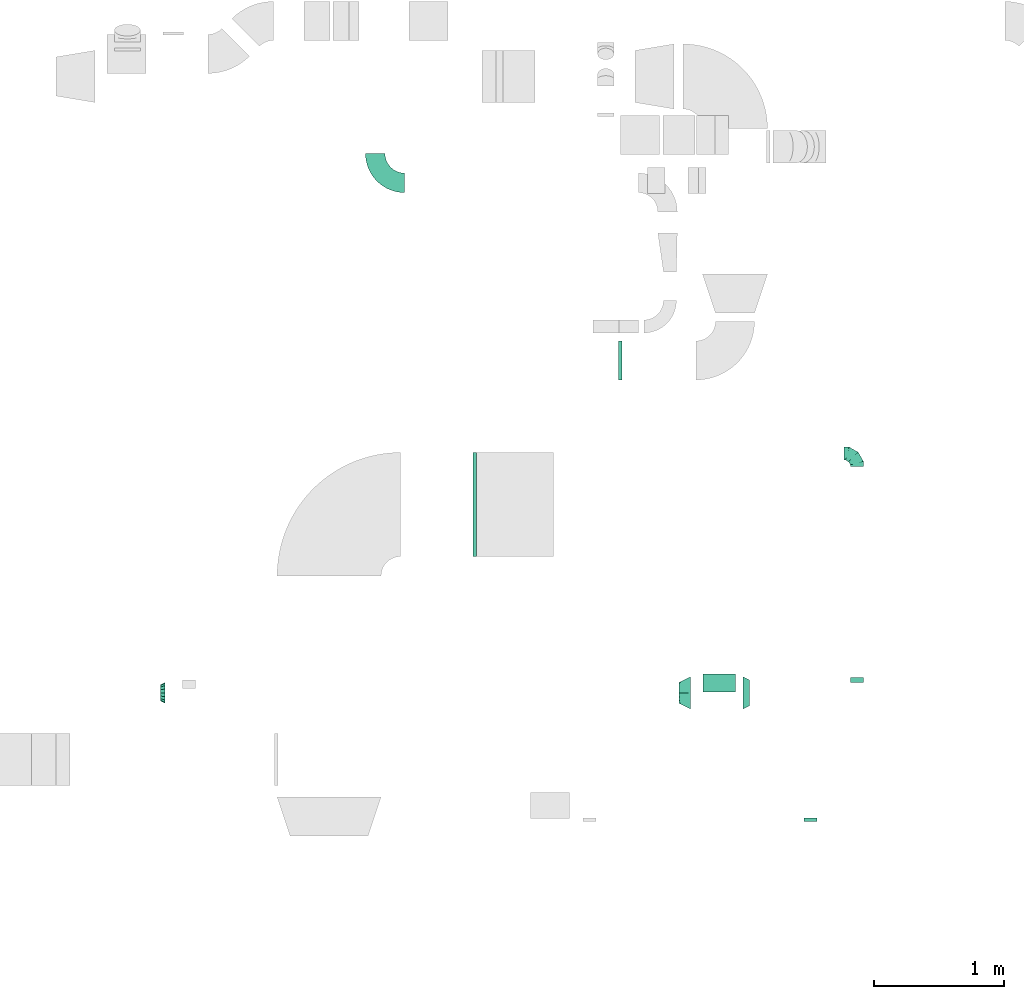
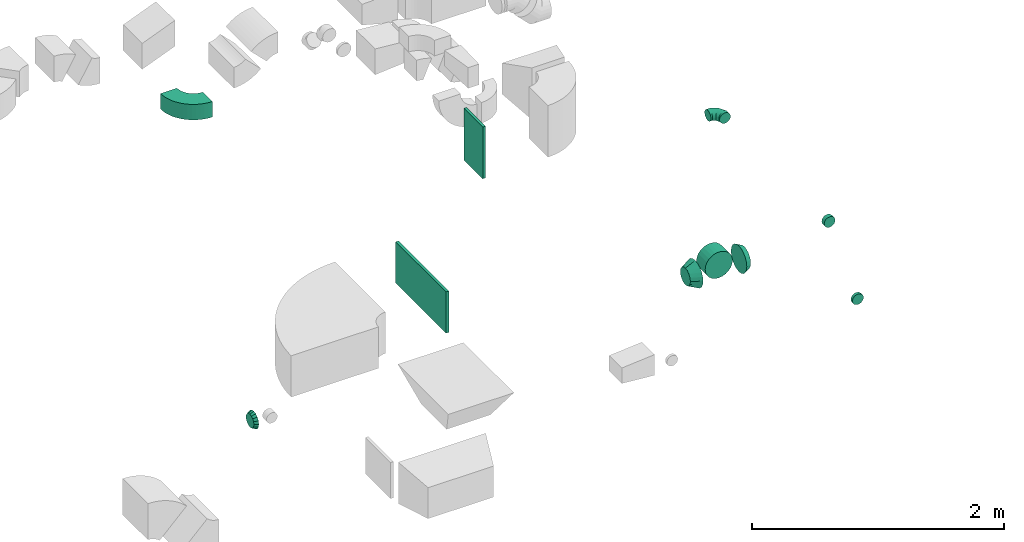
# One storey, part 25 of 44: 10 flow fittings.
"""IFC2X3 building model written with IfcOpenShell, lengths in millimetres."""

from ifc_helpers import new_model, entity, si_unit, converted_unit, derived_unit, direction, frame, frame_2d, origin, origin_2d_with_axis, place, context, subcontext, project, spatial, polyline, circle_curve, parameter, trimmed, segment, composite_curve, rectangle, outline, extrude, faceted_brep, source, transform, mapped, material, type_object, type_shapes, element, save


model = new_model("IFC2X3")

# Units and contexts
model_context = context("Model", 3, precision=0.01, world=origin(), true_north=direction((6.12303176911189e-17, 1.0)))
body_context = subcontext(model_context, "Body", "Model", "MODEL_VIEW")
ifc_project = project(units=[si_unit("LENGTHUNIT", "METRE", prefix="MILLI"), si_unit("AREAUNIT", "SQUARE_METRE"), si_unit("VOLUMEUNIT", "CUBIC_METRE"), converted_unit("PLANEANGLEUNIT", "DEGREE", entity("IfcRatioMeasure", 0.0174532925199433), si_unit("PLANEANGLEUNIT", "RADIAN"), dimensions=[0, 0, 0, 0, 0, 0, 0]), si_unit("MASSUNIT", "GRAM", prefix="KILO"), derived_unit("MASSDENSITYUNIT", [(si_unit("MASSUNIT", "GRAM", prefix="KILO"), 1), (si_unit("LENGTHUNIT", "METRE"), -3)]), derived_unit("MOMENTOFINERTIAUNIT", [(si_unit("LENGTHUNIT", "METRE"), 4)]), si_unit("TIMEUNIT", "SECOND"), si_unit("FREQUENCYUNIT", "HERTZ"), si_unit("THERMODYNAMICTEMPERATUREUNIT", "DEGREE_CELSIUS"), derived_unit("THERMALTRANSMITTANCEUNIT", [(si_unit("MASSUNIT", "GRAM", prefix="KILO"), 1), (si_unit("THERMODYNAMICTEMPERATUREUNIT", "KELVIN"), -1), (si_unit("TIMEUNIT", "SECOND"), -3)]), derived_unit("VOLUMETRICFLOWRATEUNIT", [(si_unit("LENGTHUNIT", "METRE"), 3), (si_unit("TIMEUNIT", "SECOND"), -1)]), derived_unit("MASSFLOWRATEUNIT", [(si_unit("MASSUNIT", "GRAM", prefix="KILO"), 1), (si_unit("TIMEUNIT", "SECOND"), -1)]), derived_unit("ROTATIONALFREQUENCYUNIT", [(si_unit("TIMEUNIT", "SECOND"), -1)]), si_unit("ELECTRICCURRENTUNIT", "AMPERE"), si_unit("ELECTRICVOLTAGEUNIT", "VOLT"), si_unit("POWERUNIT", "WATT"), si_unit("FORCEUNIT", "NEWTON", prefix="KILO"), si_unit("ILLUMINANCEUNIT", "LUX"), si_unit("LUMINOUSFLUXUNIT", "LUMEN"), si_unit("LUMINOUSINTENSITYUNIT", "CANDELA"), derived_unit("USERDEFINED", [(si_unit("MASSUNIT", "GRAM", prefix="KILO"), -1), (si_unit("LENGTHUNIT", "METRE"), -2), (si_unit("TIMEUNIT", "SECOND"), 3), (si_unit("LUMINOUSFLUXUNIT", "LUMEN"), 1)]), derived_unit("LINEARVELOCITYUNIT", [(si_unit("LENGTHUNIT", "METRE"), 1), (si_unit("TIMEUNIT", "SECOND"), -1)]), si_unit("PRESSUREUNIT", "PASCAL"), derived_unit("USERDEFINED", [(si_unit("LENGTHUNIT", "METRE"), -2), (si_unit("MASSUNIT", "GRAM", prefix="KILO"), 1), (si_unit("TIMEUNIT", "SECOND"), -2)]), derived_unit("LINEARFORCEUNIT", [(si_unit("MASSUNIT", "GRAM", prefix="KILO"), 1), (si_unit("LENGTHUNIT", "METRE"), 1), (si_unit("TIMEUNIT", "SECOND"), -2), (si_unit("LENGTHUNIT", "METRE"), -1)]), derived_unit("PLANARFORCEUNIT", [(si_unit("MASSUNIT", "GRAM", prefix="KILO"), 1), (si_unit("LENGTHUNIT", "METRE"), 1), (si_unit("TIMEUNIT", "SECOND"), -2), (si_unit("LENGTHUNIT", "METRE"), -2)])], contexts=[model_context])

# Site, building, storey
site_placement = place(None, origin())
site = spatial("IfcSite", under=ifc_project, at=site_placement, CompositionType="ELEMENT")
building_placement = place(site_placement, origin())
building = spatial("IfcBuilding", under=site, at=building_placement, CompositionType="ELEMENT")
storey_placement = place(building_placement, frame((0.0, 0.0, 15900.0)))
storey = spatial("IfcBuildingStorey", under=building, at=storey_placement, CompositionType="ELEMENT", Elevation=15900.0)

# Flow fittings
ifc_material = material()
duct_fitting_type_1 = type_object("IfcDuctFittingType", PredefinedType="NOTDEFINED", material=ifc_material)
shared_shape_1 = source(origin(), body_context, "Body", "SweptSolid", [
    extrude(rectangle(XDim=26.0960097170958, YDim=400.0, at=origin_2d_with_axis()), frame((6.95, 0.0, -400.0)), (0.0, 0.0, 1.0), 800.0),
])
type_shapes(duct_fitting_type_1, [shared_shape_1])
flow_fitting_1_placement = place(storey_placement, frame((51645.21, 11685.33, 2920.0), z_axis=(0.0, 1.0, 0.0), x_axis=(-1.0, 0.0, -1.21463647590417e-08)))
element("IfcFlowFitting", 1, at=flow_fitting_1_placement, inside=storey, type_object=duct_fitting_type_1, material=ifc_material, context=body_context, shape_type="MappedRepresentation", body=[
    mapped(shared_shape_1, transform((0.0, 0.0, 0.0), scale=1.0)),
])
duct_fitting_type_2 = type_object("IfcDuctFittingType", PredefinedType="NOTDEFINED", material=ifc_material)
shared_shape_2 = source(origin(), body_context, "Body", "SweptSolid", [
    extrude(rectangle(XDim=26.1144802646983, YDim=500.0, at=origin_2d_with_axis()), frame((6.96, 0.0, -150.0)), (0.0, 0.0, 1.0), 300.0),
])
type_shapes(duct_fitting_type_2, [shared_shape_2])
flow_fitting_2_placement = place(storey_placement, frame((52750.19, 12792.39, 3250.0), z_axis=(0.0, -1.0, 0.0), x_axis=(1.0, 0.0, 0.0)))
element("IfcFlowFitting", 2, at=flow_fitting_2_placement, inside=storey, type_object=duct_fitting_type_2, material=ifc_material, context=body_context, shape_type="MappedRepresentation", body=[
    mapped(shared_shape_2, transform((0.0, 0.0, 0.0), scale=1.0)),
])
duct_fitting_type_3 = type_object("IfcDuctFittingType", PredefinedType="NOTDEFINED", material=ifc_material)
shared_shape_3 = source(origin(), body_context, "Body", "Brep", [
    faceted_brep([(-100.0, 0.0, -50.0), (-100.0, -12.94, -48.3), (-100.0, -25.0, -43.3), (-100.0, -35.36, -35.36), (-100.0, -43.3, -25.0), (-100.0, -48.3, -12.94), (-100.0, -50.0, 0.0), (-100.0, -48.3, 12.94), (-100.0, -43.3, 25.0), (-100.0, -35.36, 35.36), (-100.0, -25.0, 43.3), (-100.0, -12.94, 48.3), (-100.0, 0.0, 50.0), (-100.0, 12.94, 48.3), (-100.0, 25.0, 43.3), (-100.0, 35.36, 35.36), (-100.0, 43.3, 25.0), (-100.0, 48.3, 12.94), (-100.0, 50.0, 0.0), (-100.0, 48.3, -12.94), (-100.0, 43.3, -25.0), (-100.0, 35.36, -35.36), (-100.0, 25.0, -43.3), (-100.0, 12.94, -48.3), (-76.67, 12.94, 48.3), (-79.9, 25.0, 43.3), (-73.21, 0.0, 50.0), (-82.68, 35.36, 35.36), (-86.15, 48.3, 12.94), (-86.6, 50.0, 0.0), (-84.81, 43.3, 25.0), (-84.81, 43.3, -25.0), (-82.68, 35.36, -35.36), (-86.15, 48.3, -12.94), (-76.67, 12.94, -48.3), (-73.21, 0.0, -50.0), (-79.9, 25.0, -43.3), (-69.74, -12.94, -48.3), (-66.51, -25.0, -43.3), (-63.73, -35.36, -35.36), (-61.6, -43.3, -25.0), (-60.26, -48.3, -12.94), (-59.81, -50.0, 0.0), (-60.26, -48.3, 12.94), (-61.6, -43.3, 25.0), (-63.73, -35.36, 35.36), (-66.51, -25.0, 43.3), (-69.74, -12.94, 48.3), (-36.27, 36.27, 48.3), (-45.1, 45.1, 43.3), (-26.79, 26.79, 50.0), (-52.68, 52.68, 35.36), (-58.49, 58.49, 25.0), (-62.15, 62.15, 12.94), (-63.4, 63.4, 0.0), (-62.15, 62.15, -12.94), (-58.49, 58.49, -25.0), (-52.68, 52.68, -35.36), (-36.27, 36.27, -48.3), (-26.79, 26.79, -50.0), (-45.1, 45.1, -43.3), (-17.32, 17.32, -48.3), (-8.49, 8.49, -43.3), (-0.91, 0.91, -35.36), (4.9, -4.9, -25.0), (8.56, -8.56, -12.94), (9.81, -9.81, 0.0), (8.56, -8.56, 12.94), (4.9, -4.9, 25.0), (-0.91, 0.91, 35.36), (-8.49, 8.49, 43.3), (-17.32, 17.32, 48.3), (-12.94, 76.67, 48.3), (-25.0, 79.9, 43.3), (0.0, 73.21, 50.0), (-35.36, 82.68, 35.36), (-43.3, 84.81, 25.0), (-48.3, 86.15, 12.94), (-50.0, 86.6, 0.0), (-48.3, 86.15, -12.94), (-43.3, 84.81, -25.0), (-35.36, 82.68, -35.36), (-12.94, 76.67, -48.3), (0.0, 73.21, -50.0), (-25.0, 79.9, -43.3), (12.94, 69.74, -48.3), (25.0, 66.51, -43.3), (35.36, 63.73, -35.36), (43.3, 61.6, -25.0), (48.3, 60.26, -12.94), (50.0, 59.81, 0.0), (48.3, 60.26, 12.94), (43.3, 61.6, 25.0), (35.36, 63.73, 35.36), (25.0, 66.51, 43.3), (12.94, 69.74, 48.3), (-12.94, 100.0, -48.3), (-25.0, 100.0, -43.3), (-35.36, 100.0, -35.36), (-43.3, 100.0, -25.0), (-48.3, 100.0, -12.94), (-50.0, 100.0, 0.0), (-48.3, 100.0, 12.94), (-43.3, 100.0, 25.0), (-35.36, 100.0, 35.36), (-25.0, 100.0, 43.3), (-12.94, 100.0, 48.3), (0.0, 100.0, 50.0), (12.94, 100.0, 48.3), (25.0, 100.0, 43.3), (35.36, 100.0, 35.36), (43.3, 100.0, 25.0), (48.3, 100.0, 12.94), (50.0, 100.0, 0.0), (48.3, 100.0, -12.94), (43.3, 100.0, -25.0), (35.36, 100.0, -35.36), (25.0, 100.0, -43.3), (12.94, 100.0, -48.3), (0.0, 100.0, -50.0)], [[[0, 1, 2, 3, 4, 5, 6, 7, 8, 9, 10, 11, 12, 13, 14, 15, 16, 17, 18, 19, 20, 21, 22, 23]], [[24, 25, 14, 13]], [[26, 24, 13, 12]], [[14, 25, 27, 15]], [[28, 29, 18, 17]], [[30, 28, 17, 16]], [[15, 27, 30, 16]], [[20, 31, 32, 21]], [[33, 31, 20, 19]], [[18, 29, 33, 19]], [[34, 35, 0, 23]], [[36, 34, 23, 22]], [[32, 36, 22, 21]], [[2, 1, 37, 38]], [[3, 2, 38, 39]], [[0, 35, 37, 1]], [[5, 4, 40, 41]], [[6, 5, 41, 42]], [[3, 39, 40, 4]], [[6, 42, 43, 7]], [[7, 43, 44, 8]], [[8, 44, 45, 9]], [[10, 46, 47, 11]], [[11, 47, 26, 12]], [[10, 9, 45, 46]], [[48, 49, 25, 24]], [[50, 48, 24, 26]], [[27, 25, 49, 51]], [[52, 53, 28, 30]], [[51, 52, 30, 27]], [[29, 28, 53, 54]], [[55, 56, 31, 33]], [[54, 55, 33, 29]], [[57, 32, 31, 56]], [[58, 59, 35, 34]], [[60, 58, 34, 36]], [[57, 60, 36, 32]], [[37, 35, 59, 61]], [[38, 37, 61, 62]], [[39, 38, 62, 63]], [[41, 40, 64, 65]], [[42, 41, 65, 66]], [[63, 64, 40, 39]], [[43, 42, 66, 67]], [[44, 43, 67, 68]], [[68, 69, 45, 44]], [[46, 45, 69, 70]], [[47, 46, 70, 71]], [[26, 47, 71, 50]], [[72, 73, 49, 48]], [[74, 72, 48, 50]], [[51, 49, 73, 75]], [[76, 77, 53, 52]], [[75, 76, 52, 51]], [[54, 53, 77, 78]], [[79, 80, 56, 55]], [[78, 79, 55, 54]], [[81, 57, 56, 80]], [[82, 83, 59, 58]], [[84, 82, 58, 60]], [[81, 84, 60, 57]], [[61, 59, 83, 85]], [[62, 61, 85, 86]], [[63, 62, 86, 87]], [[65, 64, 88, 89]], [[66, 65, 89, 90]], [[87, 88, 64, 63]], [[67, 66, 90, 91]], [[68, 67, 91, 92]], [[92, 93, 69, 68]], [[70, 69, 93, 94]], [[71, 70, 94, 95]], [[50, 71, 95, 74]], [[96, 97, 98, 99, 100, 101, 102, 103, 104, 105, 106, 107, 108, 109, 110, 111, 112, 113, 114, 115, 116, 117, 118, 119]], [[72, 74, 107, 106]], [[73, 72, 106, 105]], [[75, 73, 105, 104]], [[77, 76, 103, 102]], [[78, 77, 102, 101]], [[75, 104, 103, 76]], [[78, 101, 100, 79]], [[79, 100, 99, 80]], [[80, 99, 98, 81]], [[96, 119, 83, 82]], [[97, 96, 82, 84]], [[84, 81, 98, 97]], [[83, 119, 118, 85]], [[85, 118, 117, 86]], [[86, 117, 116, 87]], [[88, 115, 114, 89]], [[89, 114, 113, 90]], [[87, 116, 115, 88]], [[91, 90, 113, 112]], [[92, 91, 112, 111]], [[93, 92, 111, 110]], [[95, 94, 109, 108]], [[74, 95, 108, 107]], [[110, 109, 94, 93]]]),
])
type_shapes(duct_fitting_type_3, [shared_shape_3])
flow_fitting_3_placement = place(storey_placement, frame((54577.18, 12076.8, 3350.0), z_axis=(0.0, -5.84723969274682e-07, 1.0), x_axis=(0.0, 1.0, 5.84723969274682e-07)))
element("IfcFlowFitting", 3, at=flow_fitting_3_placement, inside=storey, type_object=duct_fitting_type_3, material=ifc_material, context=body_context, shape_type="MappedRepresentation", body=[
    mapped(shared_shape_3, transform((0.0, 0.0, 0.0), scale=1.0)),
])
duct_fitting_type_4 = type_object("IfcDuctFittingType", PredefinedType="NOTDEFINED", material=ifc_material)
shared_shape_4 = source(origin(), body_context, "Body", "Brep", [
    faceted_brep([(35.0, -57.74, 23.92), (35.0, -60.12, 11.96), (35.0, -62.5, 0.0), (35.0, -60.12, -11.96), (35.0, -57.74, -23.92), (35.0, -50.97, -34.06), (35.0, -44.19, -44.19), (35.0, -34.06, -50.97), (35.0, -23.92, -57.74), (35.0, -11.96, -60.12), (35.0, 0.0, -62.5), (35.0, 11.96, -60.12), (35.0, 23.92, -57.74), (35.0, 34.06, -50.97), (35.0, 44.19, -44.19), (35.0, 50.97, -34.06), (35.0, 57.74, -23.92), (35.0, 60.12, -11.96), (35.0, 62.5, 0.0), (35.0, 60.12, 11.96), (35.0, 57.74, 23.92), (35.0, 50.97, 34.06), (35.0, 44.19, 44.19), (35.0, 34.06, 50.97), (35.0, 23.92, 57.74), (35.0, 11.96, 60.12), (35.0, 0.0, 62.5), (35.0, -11.96, 60.12), (35.0, -23.92, 57.74), (35.0, -34.06, 50.97), (35.0, -44.19, 44.19), (35.0, -50.97, 34.06), (0.0, -80.0, 0.0), (0.0, -77.45, 12.81), (0.0, -73.91, 30.61), (0.0, -65.24, 43.59), (0.0, -56.57, 56.57), (0.0, -43.59, 65.24), (0.0, -30.61, 73.91), (0.0, -12.81, 77.45), (0.0, 0.0, 80.0), (0.0, 12.81, 77.45), (0.0, 30.61, 73.91), (0.0, 43.59, 65.24), (0.0, 56.57, 56.57), (0.0, 65.24, 43.59), (0.0, 73.91, 30.61), (0.0, 77.45, 12.81), (0.0, 80.0, 0.0), (0.0, 77.45, -12.81), (0.0, 73.91, -30.61), (0.0, 65.24, -43.59), (0.0, 56.57, -56.57), (0.0, 43.59, -65.24), (0.0, 30.61, -73.91), (0.0, 12.81, -77.45), (0.0, 0.0, -80.0), (0.0, -12.81, -77.45), (0.0, -30.61, -73.91), (0.0, -43.59, -65.24), (0.0, -56.57, -56.57), (0.0, -65.24, -43.59), (0.0, -73.91, -30.61), (0.0, -77.45, -12.81)], [[[0, 1, 2, 3, 4, 5, 6, 7, 8, 9, 10, 11, 12, 13, 14, 15, 16, 17, 18, 19, 20, 21, 22, 23, 24, 25, 26, 27, 28, 29, 30, 31]], [[32, 33, 34, 35, 36, 37, 38, 39, 40, 41, 42, 43, 44, 45, 46, 47, 48, 49, 50, 51, 52, 53, 54, 55, 56, 57, 58, 59, 60, 61, 62, 63]], [[24, 23, 22, 44, 43, 42]], [[20, 46, 45, 44, 22, 21]], [[42, 41, 40, 26, 25, 24]], [[47, 46, 20, 19, 18, 48]], [[0, 31, 30, 36, 35, 34]], [[28, 38, 37, 36, 30, 29]], [[34, 33, 32, 2, 1, 0]], [[39, 38, 28, 27, 26, 40]], [[8, 7, 6, 60, 59, 58]], [[4, 62, 61, 60, 6, 5]], [[58, 57, 56, 10, 9, 8]], [[63, 62, 4, 3, 2, 32]], [[16, 15, 14, 52, 51, 50]], [[12, 54, 53, 52, 14, 13]], [[50, 49, 48, 18, 17, 16]], [[55, 54, 12, 11, 10, 56]]]),
])
type_shapes(duct_fitting_type_4, [shared_shape_4])
flow_fitting_4_placement = place(storey_placement, frame((49259.89, 10237.4, 3350.0), z_axis=(0.0, 0.0, 1.0), x_axis=(-1.0, 0.0, 0.0)))
element("IfcFlowFitting", 4, at=flow_fitting_4_placement, inside=storey, type_object=duct_fitting_type_4, material=ifc_material, context=body_context, shape_type="MappedRepresentation", body=[
    mapped(shared_shape_4, transform((0.0, 0.0, 0.0), scale=1.0)),
])
duct_fitting_type_5 = type_object("IfcDuctFittingType", PredefinedType="NOTDEFINED", material=ifc_material)
shared_shape_5 = source(origin(), body_context, "Body", "Brep", [
    faceted_brep([(90.0, -73.91, 30.61), (90.0, -76.96, 15.31), (90.0, -80.0, 0.0), (90.0, -76.96, -15.31), (90.0, -73.91, -30.61), (90.0, -65.24, -43.59), (90.0, -56.57, -56.57), (90.0, -43.59, -65.24), (90.0, -30.61, -73.91), (90.0, -15.31, -76.96), (90.0, 0.0, -80.0), (90.0, 15.31, -76.96), (90.0, 30.61, -73.91), (90.0, 43.59, -65.24), (90.0, 56.57, -56.57), (90.0, 65.24, -43.59), (90.0, 73.91, -30.61), (90.0, 76.96, -15.31), (90.0, 80.0, 0.0), (90.0, 76.96, 15.31), (90.0, 73.91, 30.61), (90.0, 65.24, 43.59), (90.0, 56.57, 56.57), (90.0, 43.59, 65.24), (90.0, 30.61, 73.91), (90.0, 15.31, 76.96), (90.0, 0.0, 80.0), (90.0, -15.31, 76.96), (90.0, -30.61, 73.91), (90.0, -43.59, 65.24), (90.0, -56.57, 56.57), (90.0, -65.24, 43.59), (0.0, -125.0, 0.0), (0.0, -118.88, 38.63), (0.0, -101.13, 73.47), (0.0, -73.47, 101.13), (0.0, -38.63, 118.88), (0.0, 0.0, 125.0), (0.0, 38.63, 118.88), (0.0, 73.47, 101.13), (0.0, 101.13, 73.47), (0.0, 118.88, 38.63), (0.0, 125.0, 0.0), (0.0, 118.88, -38.63), (0.0, 101.13, -73.47), (0.0, 73.47, -101.13), (0.0, 38.63, -118.88), (0.0, 0.0, -125.0), (0.0, -38.63, -118.88), (0.0, -73.47, -101.13), (0.0, -101.13, -73.47), (0.0, -118.88, -38.63)], [[[0, 1, 2, 3, 4, 5, 6, 7, 8, 9, 10, 11, 12, 13, 14, 15, 16, 17, 18, 19, 20, 21, 22, 23, 24, 25, 26, 27, 28, 29, 30, 31]], [[32, 33, 34, 35, 36, 37, 38, 39, 40, 41, 42, 43, 44, 45, 46, 47, 48, 49, 50, 51]], [[37, 25, 38]], [[24, 39, 38]], [[40, 22, 21, 20]], [[23, 22, 39, 24]], [[41, 20, 19]], [[18, 42, 19]], [[25, 24, 38]], [[40, 20, 41]], [[19, 42, 41]], [[25, 37, 26]], [[22, 40, 39]], [[32, 1, 33]], [[0, 34, 33]], [[35, 30, 29, 28]], [[31, 30, 34, 0]], [[36, 28, 27]], [[26, 37, 27]], [[1, 0, 33]], [[35, 28, 36]], [[27, 37, 36]], [[1, 32, 2]], [[30, 35, 34]], [[47, 9, 48]], [[8, 49, 48]], [[50, 6, 5, 4]], [[7, 6, 49, 8]], [[51, 4, 3]], [[2, 32, 3]], [[9, 8, 48]], [[50, 4, 51]], [[3, 32, 51]], [[9, 47, 10]], [[6, 50, 49]], [[42, 17, 43]], [[16, 44, 43]], [[45, 14, 13, 12]], [[15, 14, 44, 16]], [[46, 12, 11]], [[10, 47, 11]], [[17, 16, 43]], [[45, 12, 46]], [[11, 47, 46]], [[17, 42, 18]], [[14, 45, 44]]]),
])
type_shapes(duct_fitting_type_5, [shared_shape_5])
flow_fitting_5_placement = place(storey_placement, frame((53299.89, 10237.4, 3350.0), z_axis=(0.0, 0.0, 1.0), x_axis=(-1.0, 0.0, 0.0)))
element("IfcFlowFitting", 5, at=flow_fitting_5_placement, inside=storey, type_object=duct_fitting_type_5, material=ifc_material, context=body_context, shape_type="MappedRepresentation", body=[
    mapped(shared_shape_5, transform((0.0, 0.0, 0.0), scale=1.0)),
])
duct_fitting_type_6 = type_object("IfcDuctFittingType", PredefinedType="NOTDEFINED", material=ifc_material)
shared_shape_6 = source(origin(), body_context, "Body", "Brep", [
    faceted_brep([(20.0, 0.0, -50.0), (20.0, 12.94, -48.3), (20.0, 25.0, -43.3), (20.0, 35.36, -35.36), (20.0, 43.3, -25.0), (20.0, 48.3, -12.94), (20.0, 50.0, 0.0), (20.0, 48.3, 12.94), (20.0, 43.3, 25.0), (20.0, 35.36, 35.36), (20.0, 25.0, 43.3), (20.0, 12.94, 48.3), (20.0, 0.0, 50.0), (20.0, -12.94, 48.3), (20.0, -25.0, 43.3), (20.0, -35.36, 35.36), (20.0, -43.3, 25.0), (20.0, -48.3, 12.94), (20.0, -50.0, 0.0), (20.0, -48.3, -12.94), (20.0, -43.3, -25.0), (20.0, -35.36, -35.36), (20.0, -25.0, -43.3), (20.0, -12.94, -48.3), (0.0, 0.0, 50.0), (-6.1, 0.0, 50.0), (-6.1, -12.94, 48.3), (0.0, -12.94, 48.3), (-6.1, -25.0, 43.3), (0.0, -25.0, 43.3), (0.0, -35.36, 35.36), (-6.1, -35.36, 35.36), (0.0, -43.3, 25.0), (-6.1, -43.3, 25.0), (-6.1, -48.3, 12.94), (0.0, -48.3, 12.94), (-6.1, -50.0, 0.0), (0.0, -50.0, 0.0), (-6.1, -48.3, -12.94), (0.0, -48.3, -12.94), (-6.1, -43.3, -25.0), (0.0, -43.3, -25.0), (0.0, -35.36, -35.36), (-6.1, -35.36, -35.36), (0.0, -25.0, -43.3), (-6.1, -25.0, -43.3), (-6.1, -12.94, -48.3), (0.0, -12.94, -48.3), (-6.1, 0.0, -50.0), (0.0, 0.0, -50.0), (-6.1, 12.94, -48.3), (0.0, 12.94, -48.3), (-6.1, 25.0, -43.3), (0.0, 25.0, -43.3), (0.0, 35.36, -35.36), (-6.1, 35.36, -35.36), (0.0, 43.3, -25.0), (-6.1, 43.3, -25.0), (-6.1, 48.3, -12.94), (0.0, 48.3, -12.94), (-6.1, 50.0, 0.0), (0.0, 50.0, 0.0), (-6.1, 48.3, 12.94), (0.0, 48.3, 12.94), (-6.1, 43.3, 25.0), (0.0, 43.3, 25.0), (0.0, 35.36, 35.36), (-6.1, 35.36, 35.36), (0.0, 25.0, 43.3), (-6.1, 25.0, 43.3), (-6.1, 12.94, 48.3), (0.0, 12.94, 48.3)], [[[0, 1, 2, 3, 4, 5, 6, 7, 8, 9, 10, 11, 12, 13, 14, 15, 16, 17, 18, 19, 20, 21, 22, 23]], [[13, 12, 24, 25, 26, 27]], [[14, 13, 27, 26, 28, 29]], [[30, 15, 14, 29, 28, 31]], [[17, 16, 32, 33, 34, 35]], [[18, 17, 35, 34, 36, 37]], [[32, 16, 15, 30, 31, 33]], [[19, 18, 37, 36, 38, 39]], [[20, 19, 39, 38, 40, 41]], [[42, 21, 20, 41, 40, 43]], [[23, 22, 44, 45, 46, 47]], [[0, 23, 47, 46, 48, 49]], [[44, 22, 21, 42, 43, 45]], [[1, 0, 49, 48, 50, 51]], [[2, 1, 51, 50, 52, 53]], [[54, 3, 2, 53, 52, 55]], [[5, 4, 56, 57, 58, 59]], [[6, 5, 59, 58, 60, 61]], [[56, 4, 3, 54, 55, 57]], [[7, 6, 61, 60, 62, 63]], [[8, 7, 63, 62, 64, 65]], [[66, 9, 8, 65, 64, 67]], [[11, 10, 68, 69, 70, 71]], [[12, 11, 71, 70, 25, 24]], [[68, 10, 9, 66, 67, 69]], [[46, 45, 43, 40, 38, 36, 34, 33, 31, 28, 26, 25, 70, 69, 67, 64, 62, 60, 58, 57, 55, 52, 50, 48]]]),
])
type_shapes(duct_fitting_type_6, [shared_shape_6])
flow_fitting_6_placement = place(storey_placement, frame((54219.55, 9270.12, 3375.0), z_axis=(0.0, 0.0, -1.0), x_axis=(0.0, -1.0, 0.0)))
element("IfcFlowFitting", 6, at=flow_fitting_6_placement, inside=storey, type_object=duct_fitting_type_6, material=ifc_material, context=body_context, shape_type="MappedRepresentation", body=[
    mapped(shared_shape_6, transform((0.0, 0.0, 0.0), scale=1.0)),
])
duct_fitting_type_7 = type_object("IfcDuctFittingType", PredefinedType="NOTDEFINED", material=ifc_material)
shared_shape_7 = source(origin(), body_context, "Body", "Brep", [
    faceted_brep([(20.0, 0.0, -50.0), (20.0, 12.94, -48.3), (20.0, 25.0, -43.3), (20.0, 35.36, -35.36), (20.0, 43.3, -25.0), (20.0, 48.3, -12.94), (20.0, 50.0, 0.0), (20.0, 48.3, 12.94), (20.0, 43.3, 25.0), (20.0, 35.36, 35.36), (20.0, 25.0, 43.3), (20.0, 12.94, 48.3), (20.0, 0.0, 50.0), (20.0, -12.94, 48.3), (20.0, -25.0, 43.3), (20.0, -35.36, 35.36), (20.0, -43.3, 25.0), (20.0, -48.3, 12.94), (20.0, -50.0, 0.0), (20.0, -48.3, -12.94), (20.0, -43.3, -25.0), (20.0, -35.36, -35.36), (20.0, -25.0, -43.3), (20.0, -12.94, -48.3), (0.0, 0.0, 50.0), (-19.49, 0.0, 50.0), (-19.49, -12.94, 48.3), (0.0, -12.94, 48.3), (-19.49, -25.0, 43.3), (0.0, -25.0, 43.3), (0.0, -35.36, 35.36), (-19.49, -35.36, 35.36), (0.0, -43.3, 25.0), (-19.49, -43.3, 25.0), (-19.49, -48.3, 12.94), (0.0, -48.3, 12.94), (-19.49, -50.0, 0.0), (0.0, -50.0, 0.0), (-19.49, -48.3, -12.94), (0.0, -48.3, -12.94), (-19.49, -43.3, -25.0), (0.0, -43.3, -25.0), (0.0, -35.36, -35.36), (-19.49, -35.36, -35.36), (0.0, -25.0, -43.3), (-19.49, -25.0, -43.3), (-19.49, -12.94, -48.3), (0.0, -12.94, -48.3), (-19.49, 0.0, -50.0), (0.0, 0.0, -50.0), (-19.49, 12.94, -48.3), (0.0, 12.94, -48.3), (-19.49, 25.0, -43.3), (0.0, 25.0, -43.3), (0.0, 35.36, -35.36), (-19.49, 35.36, -35.36), (0.0, 43.3, -25.0), (-19.49, 43.3, -25.0), (-19.49, 48.3, -12.94), (0.0, 48.3, -12.94), (-19.49, 50.0, 0.0), (0.0, 50.0, 0.0), (-19.49, 48.3, 12.94), (0.0, 48.3, 12.94), (-19.49, 43.3, 25.0), (0.0, 43.3, 25.0), (0.0, 35.36, 35.36), (-19.49, 35.36, 35.36), (0.0, 25.0, 43.3), (-19.49, 25.0, 43.3), (-19.49, 12.94, 48.3), (0.0, 12.94, 48.3)], [[[0, 1, 2, 3, 4, 5, 6, 7, 8, 9, 10, 11, 12, 13, 14, 15, 16, 17, 18, 19, 20, 21, 22, 23]], [[13, 12, 24, 25, 26, 27]], [[14, 13, 27, 26, 28, 29]], [[30, 15, 14, 29, 28, 31]], [[17, 16, 32, 33, 34, 35]], [[18, 17, 35, 34, 36, 37]], [[32, 16, 15, 30, 31, 33]], [[19, 18, 37, 36, 38, 39]], [[20, 19, 39, 38, 40, 41]], [[42, 21, 20, 41, 40, 43]], [[23, 22, 44, 45, 46, 47]], [[0, 23, 47, 46, 48, 49]], [[44, 22, 21, 42, 43, 45]], [[1, 0, 49, 48, 50, 51]], [[2, 1, 51, 50, 52, 53]], [[54, 3, 2, 53, 52, 55]], [[5, 4, 56, 57, 58, 59]], [[6, 5, 59, 58, 60, 61]], [[56, 4, 3, 54, 55, 57]], [[7, 6, 61, 60, 62, 63]], [[8, 7, 63, 62, 64, 65]], [[66, 9, 8, 65, 64, 67]], [[11, 10, 68, 69, 70, 71]], [[12, 11, 71, 70, 25, 24]], [[68, 10, 9, 66, 67, 69]], [[46, 45, 43, 40, 38, 36, 34, 33, 31, 28, 26, 25, 70, 69, 67, 64, 62, 60, 58, 57, 55, 52, 50, 48]]]),
])
type_shapes(duct_fitting_type_7, [shared_shape_7])
flow_fitting_7_placement = place(storey_placement, frame((54577.18, 10337.4, 3350.0), z_axis=(0.0, 5.84723967977052e-07, -1.0), x_axis=(0.0, 1.0, 5.84723967700733e-07)))
element("IfcFlowFitting", 7, at=flow_fitting_7_placement, inside=storey, type_object=duct_fitting_type_7, material=ifc_material, context=body_context, shape_type="MappedRepresentation", body=[
    mapped(shared_shape_7, transform((0.0, 0.0, 0.0), scale=1.0)),
])
duct_fitting_type_8 = type_object("IfcDuctFittingType", PredefinedType="NOTDEFINED", material=ifc_material)
shared_shape_8 = source(origin(), body_context, "Body", "Brep", [
    faceted_brep([(50.0, -73.47, -101.13), (50.0, -38.63, -118.88), (50.0, 0.0, -125.0), (50.0, 38.63, -118.88), (50.0, 73.47, -101.13), (50.0, 101.13, -73.47), (50.0, 118.88, -38.63), (50.0, 125.0, 0.0), (50.0, 118.88, 38.63), (50.0, 101.13, 73.47), (50.0, 73.47, 101.13), (50.0, 38.63, 118.88), (50.0, 0.0, 125.0), (50.0, -38.63, 118.88), (50.0, -73.47, 101.13), (50.0, -101.13, 73.47), (50.0, -118.88, 38.63), (50.0, -125.0, 0.0), (50.0, -118.88, -38.63), (50.0, -101.13, -73.47), (0.0, 30.9, -95.11), (0.0, 0.0, -100.0), (0.0, -30.9, -95.11), (0.0, -58.78, -80.9), (0.0, -80.9, -58.78), (0.0, -95.11, -30.9), (0.0, -100.0, 0.0), (0.0, -95.11, 30.9), (0.0, -80.9, 58.78), (0.0, -58.78, 80.9), (0.0, -30.9, 95.11), (0.0, 0.0, 100.0), (0.0, 30.9, 95.11), (0.0, 58.78, 80.9), (0.0, 80.9, 58.78), (0.0, 95.11, 30.9), (0.0, 100.0, 0.0), (0.0, 95.11, -30.9), (0.0, 80.9, -58.78), (0.0, 58.78, -80.9)], [[[0, 1, 2, 3, 4, 5, 6, 7, 8, 9, 10, 11, 12, 13, 14, 15, 16, 17, 18, 19]], [[20, 21, 22, 23, 24, 25, 26, 27, 28, 29, 30, 31, 32, 33, 34, 35, 36, 37, 38, 39]], [[35, 34, 9, 8]], [[36, 35, 8, 7]], [[34, 33, 10, 9]], [[10, 33, 32, 11]], [[11, 32, 31, 12]], [[30, 29, 14, 13]], [[31, 30, 13, 12]], [[29, 28, 15, 14]], [[15, 28, 27, 16]], [[16, 27, 26, 17]], [[25, 24, 19, 18]], [[26, 25, 18, 17]], [[24, 23, 0, 19]], [[0, 23, 22, 1]], [[1, 22, 21, 2]], [[20, 39, 4, 3]], [[21, 20, 3, 2]], [[39, 38, 5, 4]], [[5, 38, 37, 6]], [[6, 37, 36, 7]]]),
])
type_shapes(duct_fitting_type_8, [shared_shape_8])
flow_fitting_8_placement = place(storey_placement, frame((53749.89, 10237.4, 3350.0), z_axis=(0.0, 0.0, 1.0), x_axis=(-1.0, 0.0, 0.0)))
element("IfcFlowFitting", 8, at=flow_fitting_8_placement, inside=storey, type_object=duct_fitting_type_8, material=ifc_material, context=body_context, shape_type="MappedRepresentation", body=[
    mapped(shared_shape_8, transform((0.0, 0.0, 0.0), scale=1.0)),
])
duct_fitting_type_9 = type_object("IfcDuctFittingType", PredefinedType="NOTDEFINED", material=ifc_material)
shared_shape_9 = source(origin(), body_context, "Body", "Brep", [
    faceted_brep([(20.0, 0.0, -125.0), (20.0, 32.35, -120.74), (20.0, 62.5, -108.25), (20.0, 88.39, -88.39), (20.0, 108.25, -62.5), (20.0, 120.74, -32.35), (20.0, 125.0, 0.0), (20.0, 120.74, 32.35), (20.0, 108.25, 62.5), (20.0, 88.39, 88.39), (20.0, 62.5, 108.25), (20.0, 32.35, 120.74), (20.0, 0.0, 125.0), (20.0, -32.35, 120.74), (20.0, -62.5, 108.25), (20.0, -88.39, 88.39), (20.0, -108.25, 62.5), (20.0, -120.74, 32.35), (20.0, -125.0, 0.0), (20.0, -120.74, -32.35), (20.0, -108.25, -62.5), (20.0, -88.39, -88.39), (20.0, -62.5, -108.25), (20.0, -32.35, -120.74), (0.0, 0.0, 125.0), (-118.9, 0.0, 125.0), (-118.9, -32.35, 120.74), (0.0, -32.35, 120.74), (-118.9, -62.5, 108.25), (0.0, -62.5, 108.25), (0.0, -88.39, 88.39), (-118.9, -88.39, 88.39), (0.0, -108.25, 62.5), (-118.9, -108.25, 62.5), (-118.9, -120.74, 32.35), (0.0, -120.74, 32.35), (-118.9, -125.0, 0.0), (0.0, -125.0, 0.0), (-118.9, -120.74, -32.35), (0.0, -120.74, -32.35), (-118.9, -108.25, -62.5), (0.0, -108.25, -62.5), (0.0, -88.39, -88.39), (-118.9, -88.39, -88.39), (0.0, -62.5, -108.25), (-118.9, -62.5, -108.25), (-118.9, -32.35, -120.74), (0.0, -32.35, -120.74), (-118.9, 0.0, -125.0), (0.0, 0.0, -125.0), (-118.9, 32.35, -120.74), (0.0, 32.35, -120.74), (-118.9, 62.5, -108.25), (0.0, 62.5, -108.25), (0.0, 88.39, -88.39), (-118.9, 88.39, -88.39), (0.0, 108.25, -62.5), (-118.9, 108.25, -62.5), (-118.9, 120.74, -32.35), (0.0, 120.74, -32.35), (-118.9, 125.0, 0.0), (0.0, 125.0, 0.0), (-118.9, 120.74, 32.35), (0.0, 120.74, 32.35), (-118.9, 108.25, 62.5), (0.0, 108.25, 62.5), (0.0, 88.39, 88.39), (-118.9, 88.39, 88.39), (0.0, 62.5, 108.25), (-118.9, 62.5, 108.25), (-118.9, 32.35, 120.74), (0.0, 32.35, 120.74)], [[[0, 1, 2, 3, 4, 5, 6, 7, 8, 9, 10, 11, 12, 13, 14, 15, 16, 17, 18, 19, 20, 21, 22, 23]], [[13, 12, 24, 25, 26, 27]], [[14, 13, 27, 26, 28, 29]], [[30, 15, 14, 29, 28, 31]], [[17, 16, 32, 33, 34, 35]], [[18, 17, 35, 34, 36, 37]], [[32, 16, 15, 30, 31, 33]], [[19, 18, 37, 36, 38, 39]], [[20, 19, 39, 38, 40, 41]], [[42, 21, 20, 41, 40, 43]], [[23, 22, 44, 45, 46, 47]], [[0, 23, 47, 46, 48, 49]], [[44, 22, 21, 42, 43, 45]], [[1, 0, 49, 48, 50, 51]], [[2, 1, 51, 50, 52, 53]], [[54, 3, 2, 53, 52, 55]], [[5, 4, 56, 57, 58, 59]], [[6, 5, 59, 58, 60, 61]], [[56, 4, 3, 54, 55, 57]], [[7, 6, 61, 60, 62, 63]], [[8, 7, 63, 62, 64, 65]], [[66, 9, 8, 65, 64, 67]], [[11, 10, 68, 69, 70, 71]], [[12, 11, 71, 70, 25, 24]], [[68, 10, 9, 66, 67, 69]], [[46, 45, 43, 40, 38, 36, 34, 33, 31, 28, 26, 25, 70, 69, 67, 64, 62, 60, 58, 57, 55, 52, 50, 48]]]),
])
type_shapes(duct_fitting_type_9, [shared_shape_9])
flow_fitting_9_placement = place(storey_placement, frame((53519.89, 10362.4, 3350.0), z_axis=(0.0, 0.0, -1.0), x_axis=(0.0, 1.0, 0.0)))
element("IfcFlowFitting", 9, at=flow_fitting_9_placement, inside=storey, type_object=duct_fitting_type_9, material=ifc_material, context=body_context, shape_type="MappedRepresentation", body=[
    mapped(shared_shape_9, transform((0.0, 0.0, 0.0), scale=1.0)),
])
duct_fitting_type_10 = type_object("IfcDuctFittingType", PredefinedType="NOTDEFINED", material=ifc_material)
shared_shape_10 = source(origin(), body_context, "Body", "SweptSolid", [
    extrude(outline(composite_curve([segment(polyline([(-187.5, -112.5), (-37.5, -112.5)]), True, "CONTINUOUS"), segment(trimmed(circle_curve(frame_2d((112.5, -112.5), x_axis=(0.0, 1.0)), 150.0), [parameter(0.0)], [parameter(90.0000000000001)], True, "PARAMETER"), False, "CONTINUOUS"), segment(polyline([(112.5, 37.5), (112.5, 187.5)]), True, "CONTINUOUS"), segment(trimmed(circle_curve(frame_2d((112.5, -112.5), x_axis=(0.0, 1.0)), 300.0), [parameter(0.0)], [parameter(90.0000000000001)], True, "PARAMETER"), True, "CONTINUOUS")], self_intersect=False)), frame((-112.5, 112.5, -75.0), z_axis=(0.0, 0.0, 1.0), x_axis=(-1.0, 0.0, 0.0)), (0.0, 0.0, 1.0), 150.0),
])
type_shapes(duct_fitting_type_10, [shared_shape_10])
flow_fitting_10_placement = place(storey_placement, frame((50874.92, 14157.73, 3375.0), z_axis=(0.0, 0.0, 1.0), x_axis=(0.0, -1.0, 0.0)))
element("IfcFlowFitting", 10, at=flow_fitting_10_placement, inside=storey, type_object=duct_fitting_type_10, material=ifc_material, context=body_context, shape_type="MappedRepresentation", body=[
    mapped(shared_shape_10, transform((0.0, 0.0, 0.0), scale=1.0)),
])

save(model, "model.ifc")
